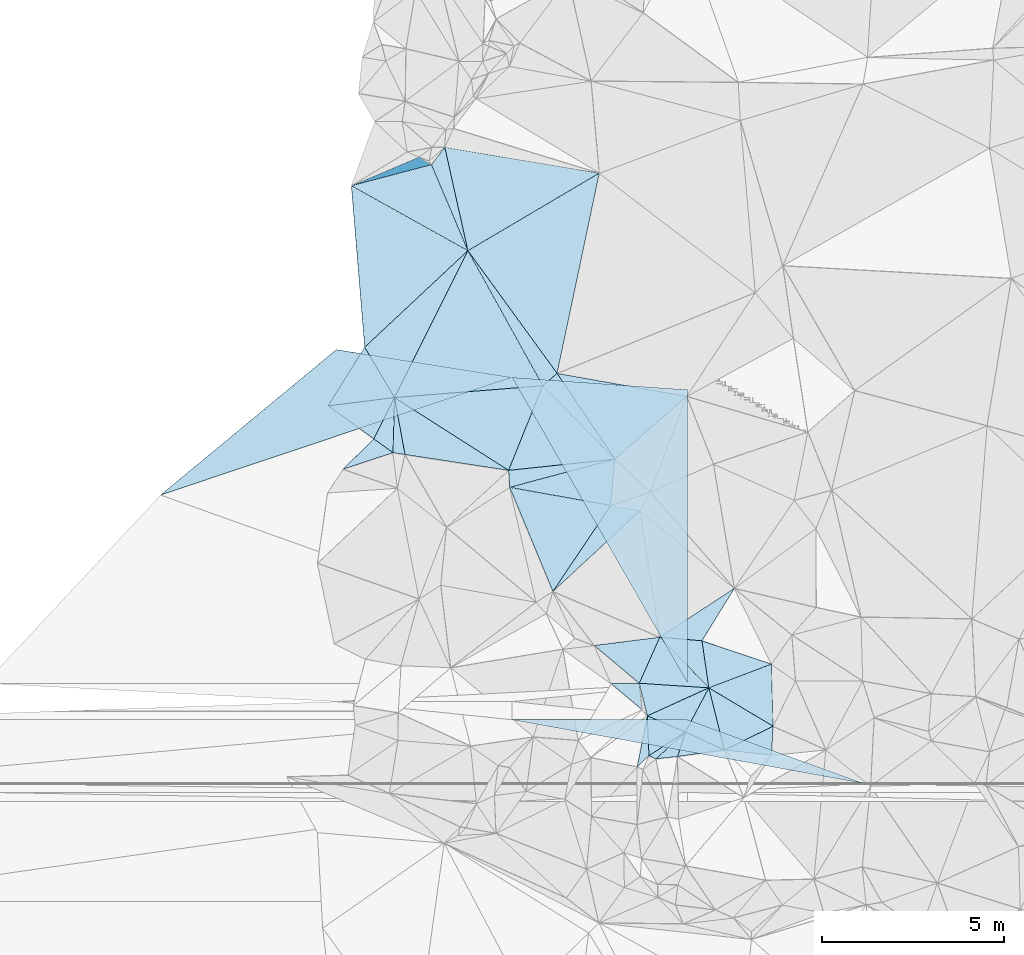
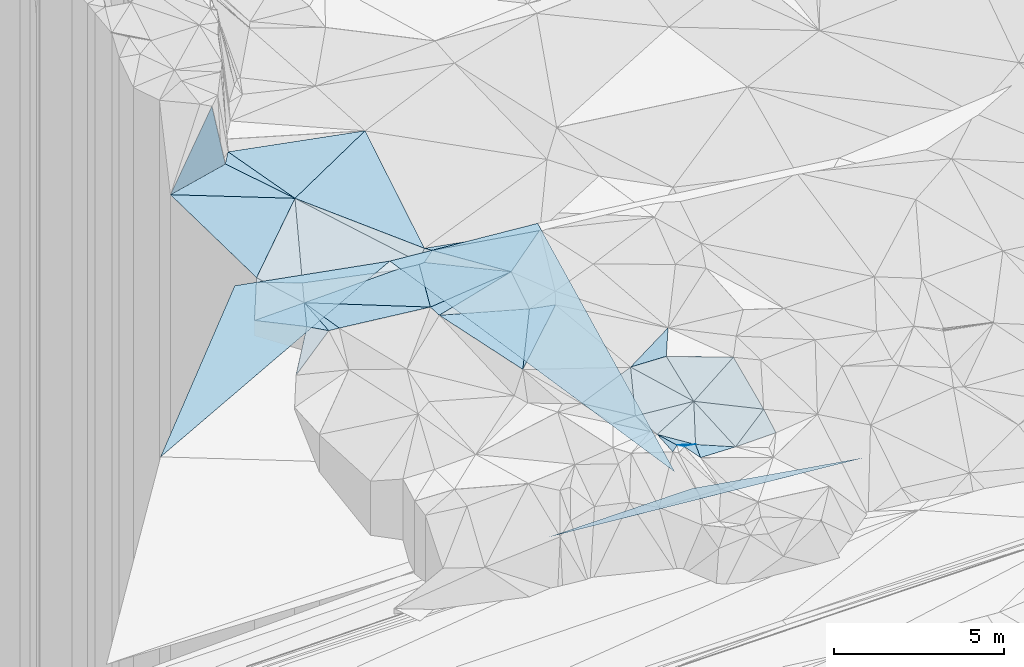
# One storey, part 68 of 275: 49 plates.
"""IFC2X3 building model written with IfcOpenShell, lengths in millimetres."""

from ifc_helpers import new_model, si_unit, frame, origin_with_axes, place, context, subcontext, project, spatial, polyline, outline, extrude, material, type_object, element, save


model = new_model("IFC2X3")

# Units and contexts
model_context = context("Model", 3, precision=1e-05, world=origin_with_axes())
body_context = subcontext(model_context, "Body", "Model", "MODEL_VIEW")
ifc_project = project(units=[si_unit("LENGTHUNIT", "METRE", prefix="MILLI"), si_unit("AREAUNIT", "SQUARE_METRE"), si_unit("VOLUMEUNIT", "CUBIC_METRE"), si_unit("MASSUNIT", "GRAM", prefix="KILO"), si_unit("TIMEUNIT", "SECOND"), si_unit("PLANEANGLEUNIT", "RADIAN"), si_unit("SOLIDANGLEUNIT", "STERADIAN"), si_unit("THERMODYNAMICTEMPERATUREUNIT", "DEGREE_CELSIUS"), si_unit("LUMINOUSINTENSITYUNIT", "LUMEN")], contexts=[model_context])

# Site, building, storey
site_placement = place(None, origin_with_axes())
site = spatial("IfcSite", under=ifc_project, at=site_placement, CompositionType="ELEMENT")
building_placement = place(site_placement, origin_with_axes())
building = spatial("IfcBuilding", under=site, at=building_placement, Name="Undefined", CompositionType="ELEMENT")
storey_placement = place(building_placement, origin_with_axes())
storey = spatial("IfcBuildingStorey", under=building, at=storey_placement, Name="Undefined", CompositionType="ELEMENT", Elevation=0.0)

# Plates
ifc_material = material()
plate_type_1 = type_object("IfcPlateType", PredefinedType="NOTDEFINED")
plate_1_placement = place(storey_placement, frame((-131876.373085821, 83332.719638965, 53049.5053031691), z_axis=(-0.0987234354850047, 0.106990906857929, -0.989346566747849), x_axis=(-0.205469038742914, -0.974971185867885, -0.0849332728995753)))
element("IfcPlate", 1, at=plate_1_placement, inside=storey, type_object=plate_type_1, material=ifc_material, Name="00", context=body_context, shape_type="SweptSolid", body=[
    extrude(outline(polyline([(0.0, 0.0), (5651.49560546875, -1.2892996892333e-08), (2812.7421875, 3119.99682617188), (0.0, 0.0)])), frame((-8.85201319254618e-08, 2.18876761149539e-07, -0.5000001331573), z_axis=(0.0, 0.0, 1.0), x_axis=(1.0, 0.0, 0.0)), (0.0, 0.0, 1.0), 1.0),
])
plate_type_2 = type_object("IfcPlateType", PredefinedType="NOTDEFINED")
plate_2_placement = place(storey_placement, frame((-137222.083942865, 75589.9858247323, 52519.5008355388), z_axis=(0.0374051977661563, 0.0450993532107701, -0.998281973953274), x_axis=(-0.987554178417872, 0.154385981878477, -0.0300285412369758)))
element("IfcPlate", 2, at=plate_2_placement, inside=storey, type_object=plate_type_2, material=ifc_material, Name="00", context=body_context, shape_type="SweptSolid", body=[
    extrude(outline(polyline([(0.0, 0.0), (333.016510009766, -2.69938027486205e-09), (524.898864746094, 1505.81579589844), (0.0, 0.0)])), frame((-8.85201319254618e-08, 2.18876761149539e-07, -0.5000001331573), z_axis=(0.0, 0.0, 1.0), x_axis=(1.0, 0.0, 0.0)), (0.0, 0.0, 1.0), 1.0),
])
plate_type_3 = type_object("IfcPlateType", PredefinedType="NOTDEFINED")
for number, where, z_axis, x_axis, name in (
    (3, (-143946.572280143, 74476.4051419111, 50913.5097885853), (0.00747221277555471, 0.447200796920443, -0.894402377719311), (0.732721959690724, 0.60621465681078, 0.309228588029591), "00_PR"),
    (4, (-143946.572280143, 74476.4051419111, 50913.5097885853), (0.00747221277555471, 0.447200796920443, -0.894402377719311), (0.732721959690724, 0.60621465681078, 0.309228588029591), "00_PR"),
    (5, (-143946.572280143, 74476.4051419111, 50913.5097885853), (0.00747221277555471, 0.447200796920443, -0.894402377719311), (0.732721959690724, 0.60621465681078, 0.309228588029591), "00_PR"),
):
    element("IfcPlate", number, at=place(storey_placement, frame(where, z_axis=z_axis, x_axis=x_axis)), inside=storey, type_object=plate_type_3, material=ifc_material, Name=name, context=body_context, shape_type="SweptSolid", body=[
        extrude(outline(polyline([(0.0, 0.0), (6597.873046875, 4.98548615723848e-08), (9570.9931640625, 3902.59301757813), (0.0, 0.0)])), frame((-8.85201319254618e-08, 2.18876761149539e-07, -0.5000001331573), z_axis=(0.0, 0.0, 1.0), x_axis=(1.0, 0.0, 0.0)), (0.0, 0.0, 1.0), 1.0),
    ])
plate_type_4 = type_object("IfcPlateType", PredefinedType="NOTDEFINED")
plate_3_placement = place(storey_placement, frame((-130777.867028294, 69298.504695003, 50919.5115253967), z_axis=(-0.0216653408171755, 0.212471242276378, -0.976927113050308), x_axis=(0.997157381322493, -0.0659406028207761, -0.0364553668710222)))
element("IfcPlate", 6, at=plate_3_placement, inside=storey, type_object=plate_type_4, material=ifc_material, Name="00", context=body_context, shape_type="SweptSolid", body=[
    extrude(outline(polyline([(0.0, 0.0), (1920.15625, -1.13504938781261e-09), (287.424530029297, 900.603759765625), (0.0, 0.0)])), frame((-8.85201319254618e-08, 2.18876761149539e-07, -0.5000001331573), z_axis=(0.0, 0.0, 1.0), x_axis=(1.0, 0.0, 0.0)), (0.0, 0.0, 1.0), 1.0),
])
plate_type_5 = type_object("IfcPlateType", PredefinedType="NOTDEFINED")
plate_4_placement = place(storey_placement, frame((-129507.213928916, 67957.8811469192, 50259.5453093224), z_axis=(0.0559457887438175, 0.412228325871965, -0.90936124618912), x_axis=(0.430634976085486, 0.811753241593706, 0.394474577297402)))
element("IfcPlate", 7, at=plate_4_placement, inside=storey, type_object=plate_type_5, material=ifc_material, Name="00", context=body_context, shape_type="SweptSolid", body=[
    extrude(outline(polyline([(0.0, 0.0), (1495.66040039063, 7.74161890149117e-09), (-5.68310832977295, 1194.18078613281), (0.0, 0.0)])), frame((-8.85201319254618e-08, 2.18876761149539e-07, -0.5000001331573), z_axis=(0.0, 0.0, 1.0), x_axis=(1.0, 0.0, 0.0)), (0.0, 0.0, 1.0), 1.0),
])
plate_type_6 = type_object("IfcPlateType", PredefinedType="NOTDEFINED")
plate_5_placement = place(storey_placement, frame((-130317.276017415, 67217.156303907, 50909.6745150053), z_axis=(-0.725862918702865, 0.222234140788264, -0.650949314401866), x_axis=(0.634845873687743, 0.580712032842833, -0.509651107693479)))
element("IfcPlate", 8, at=plate_5_placement, inside=storey, type_object=plate_type_6, material=ifc_material, Name="00", context=body_context, shape_type="SweptSolid", body=[
    extrude(outline(polyline([(0.0, 0.0), (1275.38232421875, -3.47790773957968e-09), (741.58154296875, 465.786193847656), (0.0, 0.0)])), frame((-8.85201319254618e-08, 2.18876761149539e-07, -0.5000001331573), z_axis=(0.0, 0.0, 1.0), x_axis=(1.0, 0.0, 0.0)), (0.0, 0.0, 1.0), 1.0),
])
plate_type_7 = type_object("IfcPlateType", PredefinedType="NOTDEFINED")
plate_6_placement = place(storey_placement, frame((-128863.239189452, 69172.0319425798, 50849.5744478728), z_axis=(-0.161919599291434, 0.499475163590236, -0.851062044930808), x_axis=(-0.430634976045108, -0.811753241632642, -0.394474577261359)))
element("IfcPlate", 9, at=plate_6_placement, inside=storey, type_object=plate_type_7, material=ifc_material, Name="00", context=body_context, shape_type="SweptSolid", body=[
    extrude(outline(polyline([(0.0, 0.0), (1495.66040039063, 7.74161890149117e-09), (1405.73352050781, 1225.07678222656), (0.0, 0.0)])), frame((-8.85201319254618e-08, 2.18876761149539e-07, -0.5000001331573), z_axis=(0.0, 0.0, 1.0), x_axis=(1.0, 0.0, 0.0)), (0.0, 0.0, 1.0), 1.0),
])
plate_type_8 = type_object("IfcPlateType", PredefinedType="NOTDEFINED")
plate_7_placement = place(storey_placement, frame((-130211.74865938, 70565.6825073697, 51709.5654660196), z_axis=(0.203410424775054, 0.45097816066188, -0.86904712052849), x_axis=(-0.354453549798811, -0.793478408176442, -0.494726891115493)))
element("IfcPlate", 10, at=plate_7_placement, inside=storey, type_object=plate_type_8, material=ifc_material, Name="00", context=body_context, shape_type="SweptSolid", body=[
    extrude(outline(polyline([(0.0, 0.0), (1596.84057617188, -4.36557456851006e-10), (1086.64575195313, 1552.03125), (0.0, 0.0)])), frame((-8.85201319254618e-08, 2.18876761149539e-07, -0.5000001331573), z_axis=(0.0, 0.0, 1.0), x_axis=(1.0, 0.0, 0.0)), (0.0, 0.0, 1.0), 1.0),
])
plate_type_9 = type_object("IfcPlateType", PredefinedType="NOTDEFINED")
plate_8_placement = place(storey_placement, frame((-133434.071721655, 77483.3270226593, 52429.5174317617), z_axis=(0.222725305491725, 0.137812179782694, -0.965091312465904), x_axis=(0.733911873875775, 0.627911660221034, 0.259037272110819)))
element("IfcPlate", 11, at=plate_8_placement, inside=storey, type_object=plate_type_9, material=ifc_material, Name="00", context=body_context, shape_type="SweptSolid", body=[
    extrude(outline(polyline([(0.0, 0.0), (540.462768554688, -4.65661287307739e-10), (233.688629150391, 2827.85961914063), (0.0, 0.0)])), frame((-8.85201319254618e-08, 2.18876761149539e-07, -0.5000001331573), z_axis=(0.0, 0.0, 1.0), x_axis=(1.0, 0.0, 0.0)), (0.0, 0.0, 1.0), 1.0),
])
plate_type_10 = type_object("IfcPlateType", PredefinedType="NOTDEFINED")
for number, where, z_axis, x_axis, name in (
    (12, (-129444.336182528, 69294.53261692, 48443.733790464), (0.00747221277555471, 0.447200796920443, -0.894402377719311), (-0.457576437115502, 0.796821438019943, 0.394587632989826), "00_PR"),
    (13, (-129444.336182528, 69294.53261692, 48443.733790464), (0.00747221277555471, 0.447200796920443, -0.894402377719311), (-0.457576437115502, 0.796821438019943, 0.394587632989826), "00_PR"),
    (14, (-129444.336182528, 69294.53261692, 48443.733790464), (0.00747221277555471, 0.447200796920443, -0.894402377719311), (-0.457576437115502, 0.796821438019943, 0.394587632989826), "00_PR"),
):
    element("IfcPlate", number, at=place(storey_placement, frame(where, z_axis=z_axis, x_axis=x_axis)), inside=storey, type_object=plate_type_10, material=ifc_material, Name=name, context=body_context, shape_type="SweptSolid", body=[
        extrude(outline(polyline([(0.0, 0.0), (10563.6884765625, 9.62900230661035e-08), (8029.4931640625, 4132.72900390625), (0.0, 0.0)])), frame((-8.85201319254618e-08, 2.18876761149539e-07, -0.5000001331573), z_axis=(0.0, 0.0, 1.0), x_axis=(1.0, 0.0, 0.0)), (0.0, 0.0, 1.0), 1.0),
    ])
plate_type_11 = type_object("IfcPlateType", PredefinedType="NOTDEFINED")
for number, where, z_axis, x_axis, name in (
    (15, (-134278.571251839, 68294.4644289869, 48403.4479351075), (0.00806306952558709, -0.242528174049018, -0.970110855367713), (0.999965340787191, -5.73519775278889e-05, 0.0083254990906575), "00_PR"),
    (16, (-134278.571251839, 68294.4644289869, 48403.4479351075), (0.00806306952558709, -0.242528174049018, -0.970110855367713), (0.999965340787191, -5.73519775278889e-05, 0.0083254990906575), "00_PR"),
    (17, (-134278.571251839, 68294.4644289869, 48403.4479351075), (0.00806306952558709, -0.242528174049018, -0.970110855367713), (0.999965340787191, -5.73519775278889e-05, 0.0083254990906575), "00_PR"),
):
    element("IfcPlate", number, at=place(storey_placement, frame(where, z_axis=z_axis, x_axis=x_axis)), inside=storey, type_object=plate_type_11, material=ifc_material, Name=name, context=body_context, shape_type="SweptSolid", body=[
        extrude(outline(polyline([(0.0, 0.0), (4834.345703125, 2.56695784628391e-08), (9672.3330078125, 1803.85546875), (0.0, 0.0)])), frame((-8.85201319254618e-08, 2.18876761149539e-07, -0.5000001331573), z_axis=(0.0, 0.0, 1.0), x_axis=(1.0, 0.0, 0.0)), (0.0, 0.0, 1.0), 1.0),
    ])
plate_type_12 = type_object("IfcPlateType", PredefinedType="NOTDEFINED")
plate_9_placement = place(storey_placement, frame((-128433.922147026, 67459.274378733, 50099.5510542277), z_axis=(0.120739055474049, 0.423423532521683, -0.897849983343595), x_axis=(-0.223720264294621, 0.892804646239596, 0.390959213981376)))
element("IfcPlate", 18, at=plate_9_placement, inside=storey, type_object=plate_type_12, material=ifc_material, Name="00", context=body_context, shape_type="SweptSolid", body=[
    extrude(outline(polyline([(0.0, 0.0), (1918.35864257813, 1.00117176771164e-08), (479.003234863281, 1494.77624511719), (0.0, 0.0)])), frame((-8.85201319254618e-08, 2.18876761149539e-07, -0.5000001331573), z_axis=(0.0, 0.0, 1.0), x_axis=(1.0, 0.0, 0.0)), (0.0, 0.0, 1.0), 1.0),
])
plate_type_13 = type_object("IfcPlateType", PredefinedType="NOTDEFINED")
plate_10_placement = place(storey_placement, frame((-129507.476427035, 67957.5635613176, 50259.5727044952), z_axis=(-0.469047221008928, -0.222941775111817, -0.85457104407638), x_axis=(-0.718412818824624, -0.466490694025112, 0.516013036789214)))
element("IfcPlate", 19, at=plate_10_placement, inside=storey, type_object=plate_type_13, material=ifc_material, Name="00", context=body_context, shape_type="SweptSolid", body=[
    extrude(outline(polyline([(0.0, 0.0), (1395.31359863281, 6.95581547915936e-09), (783.9814453125, 945.660095214844), (0.0, 0.0)])), frame((-8.85201319254618e-08, 2.18876761149539e-07, -0.5000001331573), z_axis=(0.0, 0.0, 1.0), x_axis=(1.0, 0.0, 0.0)), (0.0, 0.0, 1.0), 1.0),
])
plate_type_14 = type_object("IfcPlateType", PredefinedType="NOTDEFINED")
plate_11_placement = place(storey_placement, frame((-135492.116292225, 81198.423602049, 53179.500844936), z_axis=(-0.0181816866691654, 0.0555685300506669, -0.998289319154459), x_axis=(-0.389398691096374, 0.919224935599826, 0.0582595669733896)))
element("IfcPlate", 20, at=plate_11_placement, inside=storey, type_object=plate_type_14, material=ifc_material, Name="00", context=body_context, shape_type="SweptSolid", body=[
    extrude(outline(polyline([(0.0, 0.0), (2574.68432617188, 6.15546014159918e-09), (2873.55590820313, 525.429138183594), (0.0, 0.0)])), frame((-8.85201319254618e-08, 2.18876761149539e-07, -0.5000001331573), z_axis=(0.0, 0.0, 1.0), x_axis=(1.0, 0.0, 0.0)), (0.0, 0.0, 1.0), 1.0),
])
plate_type_15 = type_object("IfcPlateType", PredefinedType="NOTDEFINED")
plate_12_placement = place(storey_placement, frame((-130696.037259772, 68569.3177318687, 50769.5101196787), z_axis=(-0.0160045105613267, 0.19974210433068, -0.979717789671722), x_axis=(-0.757756307455734, 0.636851173160154, 0.142218007845653)))
element("IfcPlate", 21, at=plate_12_placement, inside=storey, type_object=plate_type_15, material=ifc_material, Name="00", context=body_context, shape_type="SweptSolid", body=[
    extrude(outline(polyline([(0.0, 0.0), (1125.03332519531, -2.25554686039686e-10), (547.717102050781, 510.78955078125), (0.0, 0.0)])), frame((-8.85201319254618e-08, 2.18876761149539e-07, -0.5000001331573), z_axis=(0.0, 0.0, 1.0), x_axis=(1.0, 0.0, 0.0)), (0.0, 0.0, 1.0), 1.0),
])
plate_type_16 = type_object("IfcPlateType", PredefinedType="NOTDEFINED")
plate_13_placement = place(storey_placement, frame((-134372.861369959, 75154.8481688772, 52539.501004332), z_axis=(0.0265862016625694, -0.0578655209280452, -0.997970317879687), x_axis=(0.373551088851921, 0.926576165126809, -0.0437743559226281)))
element("IfcPlate", 22, at=plate_13_placement, inside=storey, type_object=plate_type_16, material=ifc_material, Name="00", context=body_context, shape_type="SweptSolid", body=[
    extrude(outline(polyline([(0.0, 0.0), (2512.88671875, -1.59197952598333e-08), (1376.26574707031, 2599.90234375), (0.0, 0.0)])), frame((-8.85201319254618e-08, 2.18876761149539e-07, -0.5000001331573), z_axis=(0.0, 0.0, 1.0), x_axis=(1.0, 0.0, 0.0)), (0.0, 0.0, 1.0), 1.0),
])
plate_type_17 = type_object("IfcPlateType", PredefinedType="NOTDEFINED")
plate_14_placement = place(storey_placement, frame((-136494.81268462, 83565.5885833471, 53329.9302825221), z_axis=(-0.253461192116106, 0.957246855219389, -0.139412633084931), x_axis=(-0.966965472163252, -0.254756239300246, 0.00877691185409043)))
element("IfcPlate", 23, at=plate_14_placement, inside=storey, type_object=plate_type_17, material=ifc_material, Name="00", context=body_context, shape_type="SweptSolid", body=[
    extrude(outline(polyline([(0.0, 0.0), (2278.70581054688, 1.88738340511918e-08), (287.531646728516, 2087.94775390625), (0.0, 0.0)])), frame((-8.85201319254618e-08, 2.18876761149539e-07, -0.5000001331573), z_axis=(0.0, 0.0, 1.0), x_axis=(1.0, 0.0, 0.0)), (0.0, 0.0, 1.0), 1.0),
])
plate_type_18 = type_object("IfcPlateType", PredefinedType="NOTDEFINED")
plate_15_placement = place(storey_placement, frame((-135492.048572748, 81198.5250785127, 53179.5205579998), z_axis=(0.117251982831661, 0.258521524463737, -0.95886317788879), x_axis=(0.581906415110403, -0.800295000720476, -0.144612709936484)))
element("IfcPlate", 24, at=plate_15_placement, inside=storey, type_object=plate_type_18, material=ifc_material, Name="00", context=body_context, shape_type="SweptSolid", body=[
    extrude(outline(polyline([(0.0, 0.0), (4218.1630859375, -3.72674548998475e-08), (4279.18505859375, 537.0068359375), (0.0, 0.0)])), frame((-8.85201319254618e-08, 2.18876761149539e-07, -0.5000001331573), z_axis=(0.0, 0.0, 1.0), x_axis=(1.0, 0.0, 0.0)), (0.0, 0.0, 1.0), 1.0),
])
plate_type_19 = type_object("IfcPlateType", PredefinedType="NOTDEFINED")
plate_16_placement = place(storey_placement, frame((-131448.098328268, 75463.8641867676, 52599.501893676), z_axis=(-0.0658925266746313, -0.0570730027535279, -0.996193177694532), x_axis=(-0.558795280066664, 0.829238565725981, -0.0105468520391548)))
element("IfcPlate", 25, at=plate_16_placement, inside=storey, type_object=plate_type_19, material=ifc_material, Name="00", context=body_context, shape_type="SweptSolid", body=[
    extrude(outline(polyline([(0.0, 0.0), (2844.45068359375, -1.2136297300458e-08), (329.026611328125, 2617.8505859375), (0.0, 0.0)])), frame((-8.85201319254618e-08, 2.18876761149539e-07, -0.5000001331573), z_axis=(0.0, 0.0, 1.0), x_axis=(1.0, 0.0, 0.0)), (0.0, 0.0, 1.0), 1.0),
])
plate_type_20 = type_object("IfcPlateType", PredefinedType="NOTDEFINED")
plate_17_placement = place(storey_placement, frame((-131448.10394559, 75464.0839332965, 52599.5396083196), z_axis=(-0.0771277890794112, 0.382419203517881, -0.92076427870138), x_axis=(-0.0826434597283267, -0.92278928073043, -0.376337616952049)))
element("IfcPlate", 26, at=plate_17_placement, inside=storey, type_object=plate_type_20, material=ifc_material, Name="00", context=body_context, shape_type="SweptSolid", body=[
    extrude(outline(polyline([(0.0, 0.0), (1381.73803710938, -1.00990291684866e-08), (985.425598144531, 2829.93579101563), (0.0, 0.0)])), frame((-8.85201319254618e-08, 2.18876761149539e-07, -0.5000001331573), z_axis=(0.0, 0.0, 1.0), x_axis=(1.0, 0.0, 0.0)), (0.0, 0.0, 1.0), 1.0),
])
plate_type_21 = type_object("IfcPlateType", PredefinedType="NOTDEFINED")
plate_18_placement = place(storey_placement, frame((-138331.204889534, 78543.8518562876, 52929.5114152895), z_axis=(-0.0984354771261939, 0.188391484193113, -0.977148456237052), x_axis=(0.497765814191245, -0.840933550853854, -0.212273307956642)))
element("IfcPlate", 27, at=plate_18_placement, inside=storey, type_object=plate_type_21, material=ifc_material, Name="00", context=body_context, shape_type="SweptSolid", body=[
    extrude(outline(polyline([(0.0, 0.0), (1648.81774902344, 1.4202669262886e-08), (901.979614257813, 1685.32873535156), (0.0, 0.0)])), frame((-8.85201319254618e-08, 2.18876761149539e-07, -0.5000001331573), z_axis=(0.0, 0.0, 1.0), x_axis=(1.0, 0.0, 0.0)), (0.0, 0.0, 1.0), 1.0),
])
plate_type_22 = type_object("IfcPlateType", PredefinedType="NOTDEFINED")
plate_19_placement = place(storey_placement, frame((-134341.363470245, 74687.8365379554, 52519.510689617), z_axis=(-0.125655298931122, 0.163097169042989, -0.97857552559866), x_axis=(0.972526210972817, -0.1745953888228, -0.153977982752961)))
element("IfcPlate", 28, at=plate_19_placement, inside=storey, type_object=plate_type_22, material=ifc_material, Name="00", context=body_context, shape_type="SweptSolid", body=[
    extrude(outline(polyline([(0.0, 0.0), (2857.55151367188, -3.40078258886933e-08), (1753.7392578125, 2633.66650390625), (0.0, 0.0)])), frame((-8.85201319254618e-08, 2.18876761149539e-07, -0.5000001331573), z_axis=(0.0, 0.0, 1.0), x_axis=(1.0, 0.0, 0.0)), (0.0, 0.0, 1.0), 1.0),
])
plate_type_23 = type_object("IfcPlateType", PredefinedType="NOTDEFINED")
plate_20_placement = place(storey_placement, frame((-134372.868051631, 75154.897443325, 52539.5004472569), z_axis=(0.0132252414913027, 0.0406816757655235, -0.999084628169409), x_axis=(-0.988517091714467, 0.1509496997619, -0.00693884213421389)))
element("IfcPlate", 29, at=plate_20_placement, inside=storey, type_object=plate_type_23, material=ifc_material, Name="00", context=body_context, shape_type="SweptSolid", body=[
    extrude(outline(polyline([(0.0, 0.0), (2882.32543945313, -8.68021743372083e-09), (3403.501953125, 1507.10815429688), (0.0, 0.0)])), frame((-8.85201319254618e-08, 2.18876761149539e-07, -0.5000001331573), z_axis=(0.0, 0.0, 1.0), x_axis=(1.0, 0.0, 0.0)), (0.0, 0.0, 1.0), 1.0),
])
plate_type_24 = type_object("IfcPlateType", PredefinedType="NOTDEFINED")
plate_21_placement = place(storey_placement, frame((-128160.226714063, 71909.7491631853, 51589.5040158838), z_axis=(0.0235184124547525, -0.12443485204428, -0.991949016770684), x_axis=(-0.523315727872897, -0.84695627113523, 0.0938388179037154)))
element("IfcPlate", 30, at=plate_21_placement, inside=storey, type_object=plate_type_24, material=ifc_material, Name="00", context=body_context, shape_type="SweptSolid", body=[
    extrude(outline(polyline([(0.0, 0.0), (1705.05126953125, 2.03726813197136e-09), (2223.5107421875, 1042.49694824219), (0.0, 0.0)])), frame((-8.85201319254618e-08, 2.18876761149539e-07, -0.5000001331573), z_axis=(0.0, 0.0, 1.0), x_axis=(1.0, 0.0, 0.0)), (0.0, 0.0, 1.0), 1.0),
])
plate_type_25 = type_object("IfcPlateType", PredefinedType="NOTDEFINED")
plate_22_placement = place(storey_placement, frame((-137550.837436567, 75641.6683647271, 52509.6179659055), z_axis=(0.274106104733879, 0.584036761802709, -0.764046401870086), x_axis=(-0.821084321079861, -0.271500444217011, -0.50210362124445)))
element("IfcPlate", 31, at=plate_22_placement, inside=storey, type_object=plate_type_25, material=ifc_material, Name="00", context=body_context, shape_type="SweptSolid", body=[
    extrude(outline(polyline([(0.0, 0.0), (1672.96142578125, 1.88592821359634e-08), (280.699829101563, 594.733215332031), (0.0, 0.0)])), frame((-8.85201319254618e-08, 2.18876761149539e-07, -0.5000001331573), z_axis=(0.0, 0.0, 1.0), x_axis=(1.0, 0.0, 0.0)), (0.0, 0.0, 1.0), 1.0),
])
plate_type_26 = type_object("IfcPlateType", PredefinedType="NOTDEFINED")
plate_23_placement = place(storey_placement, frame((-129052.488142068, 70465.9954511238, 51749.5923875221), z_axis=(0.0610130454411398, 0.575950822932955, -0.815204304361091), x_axis=(0.937111533130734, -0.314250180829959, -0.151884160865126)))
element("IfcPlate", 32, at=plate_23_placement, inside=storey, type_object=plate_type_26, material=ifc_material, Name="00", context=body_context, shape_type="SweptSolid", body=[
    extrude(outline(polyline([(0.0, 0.0), (2041.02917480469, 3.92901711165905e-10), (720.763854980469, 1414.42553710938), (0.0, 0.0)])), frame((-8.85201319254618e-08, 2.18876761149539e-07, -0.5000001331573), z_axis=(0.0, 0.0, 1.0), x_axis=(1.0, 0.0, 0.0)), (0.0, 0.0, 1.0), 1.0),
])
plate_type_27 = type_object("IfcPlateType", PredefinedType="NOTDEFINED")
plate_24_placement = place(storey_placement, frame((-128863.156297299, 69172.04611385, 50849.5753201901), z_axis=(0.00385368191806774, 0.527833923318115, -0.849338859661019), x_axis=(-0.997157381323825, 0.0659406028076127, 0.0364553668583891)))
element("IfcPlate", 33, at=plate_24_placement, inside=storey, type_object=plate_type_27, material=ifc_material, Name="00", context=body_context, shape_type="SweptSolid", body=[
    extrude(outline(polyline([(0.0, 0.0), (1920.15625, -1.13504938781261e-09), (1468.10974121094, 1531.52014160156), (0.0, 0.0)])), frame((-8.85201319254618e-08, 2.18876761149539e-07, -0.5000001331573), z_axis=(0.0, 0.0, 1.0), x_axis=(1.0, 0.0, 0.0)), (0.0, 0.0, 1.0), 1.0),
])
plate_type_28 = type_object("IfcPlateType", PredefinedType="NOTDEFINED")
plate_25_placement = place(storey_placement, frame((-127095.40854029, 68116.6074368234, 50589.5455203975), z_axis=(0.139850192785878, 0.392774936488339, -0.908938816887217), x_axis=(-0.0484990117565246, -0.914140943246959, -0.402485008091234)))
element("IfcPlate", 34, at=plate_25_placement, inside=storey, type_object=plate_type_28, material=ifc_material, Name="00", context=body_context, shape_type="SweptSolid", body=[
    extrude(outline(polyline([(0.0, 0.0), (869.597595214844, -4.48198989033699e-09), (863.042846679688, 1311.08996582031), (0.0, 0.0)])), frame((-8.85201319254618e-08, 2.18876761149539e-07, -0.5000001331573), z_axis=(0.0, 0.0, 1.0), x_axis=(1.0, 0.0, 0.0)), (0.0, 0.0, 1.0), 1.0),
])
plate_type_29 = type_object("IfcPlateType", PredefinedType="NOTDEFINED")
plate_26_placement = place(storey_placement, frame((-128863.090731118, 69172.0043445049, 50849.5571617167), z_axis=(0.134988255293971, 0.444286144163471, -0.885656814481233), x_axis=(0.890662720372835, 0.337249225955792, 0.304930939936044)))
element("IfcPlate", 35, at=plate_26_placement, inside=storey, type_object=plate_type_29, material=ifc_material, Name="00", context=body_context, shape_type="SweptSolid", body=[
    extrude(outline(polyline([(0.0, 0.0), (1934.86437988281, 1.11176632344723e-08), (1139.20129394531, 1734.45104980469), (0.0, 0.0)])), frame((-8.85201319254618e-08, 2.18876761149539e-07, -0.5000001331573), z_axis=(0.0, 0.0, 1.0), x_axis=(1.0, 0.0, 0.0)), (0.0, 0.0, 1.0), 1.0),
])
plate_type_30 = type_object("IfcPlateType", PredefinedType="NOTDEFINED")
plate_27_placement = place(storey_placement, frame((-129722.872417627, 67282.9058950774, 50269.5047363378), z_axis=(-0.134518702167335, 0.0282938537216017, -0.990507030065308), x_axis=(0.30427491092417, 0.952479677317607, -0.0141153419737528)))
element("IfcPlate", 36, at=plate_27_placement, inside=storey, type_object=plate_type_30, material=ifc_material, Name="00", context=body_context, shape_type="SweptSolid", body=[
    extrude(outline(polyline([(0.0, 0.0), (708.449035644531, 4.68571670353413e-09), (562.355224609375, 1185.22424316406), (0.0, 0.0)])), frame((-8.85201319254618e-08, 2.18876761149539e-07, -0.5000001331573), z_axis=(0.0, 0.0, 1.0), x_axis=(1.0, 0.0, 0.0)), (0.0, 0.0, 1.0), 1.0),
])
plate_type_31 = type_object("IfcPlateType", PredefinedType="NOTDEFINED")
plate_28_placement = place(storey_placement, frame((-130556.221995115, 68401.2962574812, 50719.5136850839), z_axis=(0.0373461778400273, -0.229426377902041, -0.9726092741299), x_axis=(0.0413724031770239, -0.972098771364882, 0.230894571106048)))
element("IfcPlate", 37, at=plate_28_placement, inside=storey, type_object=plate_type_31, material=ifc_material, Name="00", context=body_context, shape_type="SweptSolid", body=[
    extrude(outline(polyline([(0.0, 0.0), (1126.05505371094, -7.71251507103443e-10), (1424.97473144531, 336.373352050781), (0.0, 0.0)])), frame((-8.85201319254618e-08, 2.18876761149539e-07, -0.5000001331573), z_axis=(0.0, 0.0, 1.0), x_axis=(1.0, 0.0, 0.0)), (0.0, 0.0, 1.0), 1.0),
])
plate_type_32 = type_object("IfcPlateType", PredefinedType="NOTDEFINED")
plate_29_placement = place(storey_placement, frame((-129507.46093777, 67957.5386332055, 50259.5717096213), z_axis=(-0.438083777020322, -0.272804349603202, -0.856539777914128), x_axis=(-0.63484587372109, -0.580712032802745, 0.509651107697619)))
element("IfcPlate", 38, at=plate_29_placement, inside=storey, type_object=plate_type_32, material=ifc_material, Name="00", context=body_context, shape_type="SweptSolid", body=[
    extrude(outline(polyline([(0.0, 0.0), (1275.38232421875, -3.47790773957968e-09), (1381.31127929688, 197.177688598633), (0.0, 0.0)])), frame((-8.85201319254618e-08, 2.18876761149539e-07, -0.5000001331573), z_axis=(0.0, 0.0, 1.0), x_axis=(1.0, 0.0, 0.0)), (0.0, 0.0, 1.0), 1.0),
])
plate_type_33 = type_object("IfcPlateType", PredefinedType="NOTDEFINED")
plate_30_placement = place(storey_placement, frame((-137510.477129558, 77157.3072821828, 52579.511444882), z_axis=(-0.0930673011416788, 0.191546947246173, -0.977061023917583), x_axis=(-0.497765814227686, 0.840933550879775, 0.212273307768503)))
element("IfcPlate", 39, at=plate_30_placement, inside=storey, type_object=plate_type_33, material=ifc_material, Name="00", context=body_context, shape_type="SweptSolid", body=[
    extrude(outline(polyline([(0.0, 0.0), (1648.81774902344, 1.4202669262886e-08), (2521.0791015625, 3795.91357421875), (0.0, 0.0)])), frame((-8.85201319254618e-08, 2.18876761149539e-07, -0.5000001331573), z_axis=(0.0, 0.0, 1.0), x_axis=(1.0, 0.0, 0.0)), (0.0, 0.0, 1.0), 1.0),
])
plate_type_34 = type_object("IfcPlateType", PredefinedType="NOTDEFINED")
plate_31_placement = place(storey_placement, frame((-128863.119388061, 69172.0706682629, 50849.5934318841), z_axis=(0.0776927727474992, 0.576924188268413, -0.813094283618842), x_axis=(-0.635716004200721, 0.656918922923443, 0.405367352790247)))
element("IfcPlate", 40, at=plate_31_placement, inside=storey, type_object=plate_type_34, material=ifc_material, Name="00", context=body_context, shape_type="SweptSolid", body=[
    extrude(outline(polyline([(0.0, 0.0), (2121.53247070313, 6.83940015733242e-10), (1335.21411132813, 858.663696289063), (0.0, 0.0)])), frame((-8.85201319254618e-08, 2.18876761149539e-07, -0.5000001331573), z_axis=(0.0, 0.0, 1.0), x_axis=(1.0, 0.0, 0.0)), (0.0, 0.0, 1.0), 1.0),
])
plate_type_35 = type_object("IfcPlateType", PredefinedType="NOTDEFINED")
plate_32_placement = place(storey_placement, frame((-133151.878984966, 71824.2227560117, 51889.5033473761), z_axis=(-0.0419792522018825, 0.108027666482196, -0.993261176961519), x_axis=(0.556655869864603, 0.828074449149523, 0.06653532303217)))
element("IfcPlate", 41, at=plate_32_placement, inside=storey, type_object=plate_type_35, material=ifc_material, Name="00", context=body_context, shape_type="SweptSolid", body=[
    extrude(outline(polyline([(0.0, 0.0), (2855.6259765625, -2.36614141613245e-08), (3181.333984375, 755.2578125), (0.0, 0.0)])), frame((-8.85201319254618e-08, 2.18876761149539e-07, -0.5000001331573), z_axis=(0.0, 0.0, 1.0), x_axis=(1.0, 0.0, 0.0)), (0.0, 0.0, 1.0), 1.0),
])
plate_type_36 = type_object("IfcPlateType", PredefinedType="NOTDEFINED")
plate_33_placement = place(storey_placement, frame((-134341.292710237, 74687.7769103002, 52519.5005209714), z_axis=(0.0158599267635388, 0.043840814579353, -0.998912631665089), x_axis=(-0.067377352201302, 0.996814325134933, 0.0426789598763862)))
element("IfcPlate", 42, at=plate_33_placement, inside=storey, type_object=plate_type_36, material=ifc_material, Name="00", context=body_context, shape_type="SweptSolid", body=[
    extrude(outline(polyline([(0.0, 0.0), (468.614990234375, -1.94995664060116e-09), (582.140991210938, 2939.5087890625), (0.0, 0.0)])), frame((-8.85201319254618e-08, 2.18876761149539e-07, -0.5000001331573), z_axis=(0.0, 0.0, 1.0), x_axis=(1.0, 0.0, 0.0)), (0.0, 0.0, 1.0), 1.0),
])
plate_type_37 = type_object("IfcPlateType", PredefinedType="NOTDEFINED")
plate_34_placement = place(storey_placement, frame((-137510.447614768, 77157.1947782141, 52579.5005465209), z_axis=(-0.034081055353988, -0.0334493833614843, -0.998859159450768), x_axis=(0.996146367776948, 0.0796787121691029, -0.0366567427885499)))
element("IfcPlate", 43, at=plate_34_placement, inside=storey, type_object=plate_type_37, material=ifc_material, Name="00", context=body_context, shape_type="SweptSolid", body=[
    extrude(outline(polyline([(0.0, 0.0), (4092.0166015625, 4.01778379455209e-08), (2967.3876953125, 2247.17822265625), (0.0, 0.0)])), frame((-8.85201319254618e-08, 2.18876761149539e-07, -0.5000001331573), z_axis=(0.0, 0.0, 1.0), x_axis=(1.0, 0.0, 0.0)), (0.0, 0.0, 1.0), 1.0),
])
plate_type_38 = type_object("IfcPlateType", PredefinedType="NOTDEFINED")
plate_35_placement = place(storey_placement, frame((-138079.266328313, 76020.1293636034, 52609.5015441689), z_axis=(-0.0781014770091496, 0.0127676537946382, -0.996863654822248), x_axis=(-0.807533081742371, 0.585561483559626, 0.0707677247275834)))
element("IfcPlate", 44, at=plate_35_placement, inside=storey, type_object=plate_type_38, material=ifc_material, Name="00", context=body_context, shape_type="SweptSolid", body=[
    extrude(outline(polyline([(0.0, 0.0), (1554.380859375, -1.3646058505401e-08), (204.390060424805, 1255.23889160156), (0.0, 0.0)])), frame((-8.85201319254618e-08, 2.18876761149539e-07, -0.5000001331573), z_axis=(0.0, 0.0, 1.0), x_axis=(1.0, 0.0, 0.0)), (0.0, 0.0, 1.0), 1.0),
])
plate_type_39 = type_object("IfcPlateType", PredefinedType="NOTDEFINED")
plate_36_placement = place(storey_placement, frame((-137510.506226073, 77157.2363219587, 52579.5063557115), z_axis=(-0.151299423427961, 0.0496367554351851, -0.98724094170584), x_axis=(-0.0267089187779195, -0.998579077715648, -0.0461135468846323)))
element("IfcPlate", 45, at=plate_36_placement, inside=storey, type_object=plate_type_39, material=ifc_material, Name="00", context=body_context, shape_type="SweptSolid", body=[
    extrude(outline(polyline([(0.0, 0.0), (1517.99206542969, -8.00355337560177e-09), (1149.28137207031, 544.566223144531), (0.0, 0.0)])), frame((-8.85201319254618e-08, 2.18876761149539e-07, -0.5000001331573), z_axis=(0.0, 0.0, 1.0), x_axis=(1.0, 0.0, 0.0)), (0.0, 0.0, 1.0), 1.0),
])
plate_type_40 = type_object("IfcPlateType", PredefinedType="NOTDEFINED")
plate_37_placement = place(storey_placement, frame((-135492.132161658, 81198.4813462362, 53179.5079739984), z_axis=(-0.04988875472802, 0.171012886741823, -0.984004931247763), x_axis=(0.477172297334341, -0.861431563157831, -0.173903020825181)))
element("IfcPlate", 46, at=plate_37_placement, inside=storey, type_object=plate_type_40, material=ifc_material, Name="00", context=body_context, shape_type="SweptSolid", body=[
    extrude(outline(polyline([(0.0, 0.0), (4312.74853515625, -1.30967237055302e-09), (2622.45751953125, 3726.595703125), (0.0, 0.0)])), frame((-8.85201319254618e-08, 2.18876761149539e-07, -0.5000001331573), z_axis=(0.0, 0.0, 1.0), x_axis=(1.0, 0.0, 0.0)), (0.0, 0.0, 1.0), 1.0),
])
plate_type_41 = type_object("IfcPlateType", PredefinedType="NOTDEFINED")
plate_38_placement = place(storey_placement, frame((-135492.107393884, 81198.4429052236, 53179.5021958812), z_axis=(-0.000347339684913059, 0.0941281287279756, -0.995560030704986), x_axis=(-0.728925057787513, -0.681577752096881, -0.0641874440683914)))
element("IfcPlate", 47, at=plate_38_placement, inside=storey, type_object=plate_type_41, material=ifc_material, Name="00", context=body_context, shape_type="SweptSolid", body=[
    extrude(outline(polyline([(0.0, 0.0), (3894.8427734375, 3.03261913359165e-08), (1108.59423828125, 3502.70166015625), (0.0, 0.0)])), frame((-8.85201319254618e-08, 2.18876761149539e-07, -0.5000001331573), z_axis=(0.0, 0.0, 1.0), x_axis=(1.0, 0.0, 0.0)), (0.0, 0.0, 1.0), 1.0),
])
plate_type_42 = type_object("IfcPlateType", PredefinedType="NOTDEFINED")
plate_39_placement = place(storey_placement, frame((-136127.23519231, 84044.6709424477, 53349.5014795082), z_axis=(-0.0627319887140449, 0.0455502465106979, -0.996990407493871), x_axis=(0.983881409727755, -0.164790786743085, -0.0694360727339947)))
element("IfcPlate", 48, at=plate_39_placement, inside=storey, type_object=plate_type_42, material=ifc_material, Name="00", context=body_context, shape_type="SweptSolid", body=[
    extrude(outline(polyline([(0.0, 0.0), (4320.52099609375, -4.93528204970062e-08), (1105.70007324219, 2703.85424804688), (0.0, 0.0)])), frame((-8.85201319254618e-08, 2.18876761149539e-07, -0.5000001331573), z_axis=(0.0, 0.0, 1.0), x_axis=(1.0, 0.0, 0.0)), (0.0, 0.0, 1.0), 1.0),
])
plate_type_43 = type_object("IfcPlateType", PredefinedType="NOTDEFINED")
plate_40_placement = place(storey_placement, frame((-138698.127416126, 82984.6222010927, 53349.5008150371), z_axis=(-0.02314739661231, 0.0534657376741949, -0.998301363780009), x_axis=(0.966965472057431, 0.25475623970413, -0.00877691178950293)))
element("IfcPlate", 49, at=plate_40_placement, inside=storey, type_object=plate_type_43, material=ifc_material, Name="00", context=body_context, shape_type="SweptSolid", body=[
    extrude(outline(polyline([(0.0, 0.0), (2278.70581054688, 1.88738340511918e-08), (2646.54614257813, 2548.27270507813), (0.0, 0.0)])), frame((-8.85201319254618e-08, 2.18876761149539e-07, -0.5000001331573), z_axis=(0.0, 0.0, 1.0), x_axis=(1.0, 0.0, 0.0)), (0.0, 0.0, 1.0), 1.0),
])

save(model, "model.ifc")
